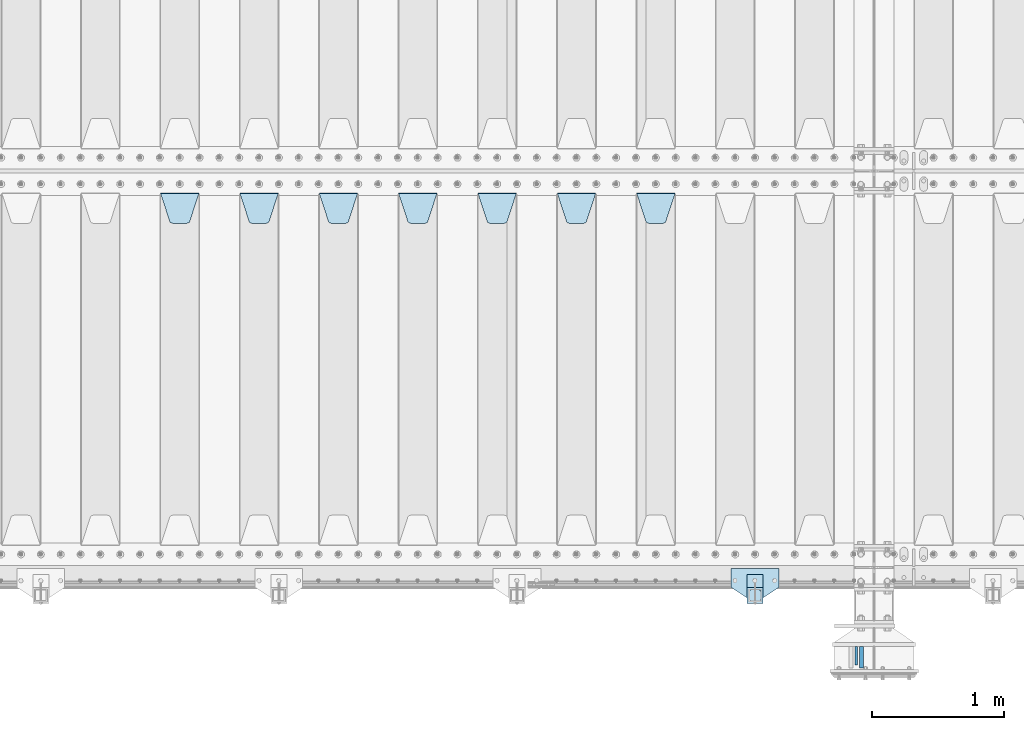
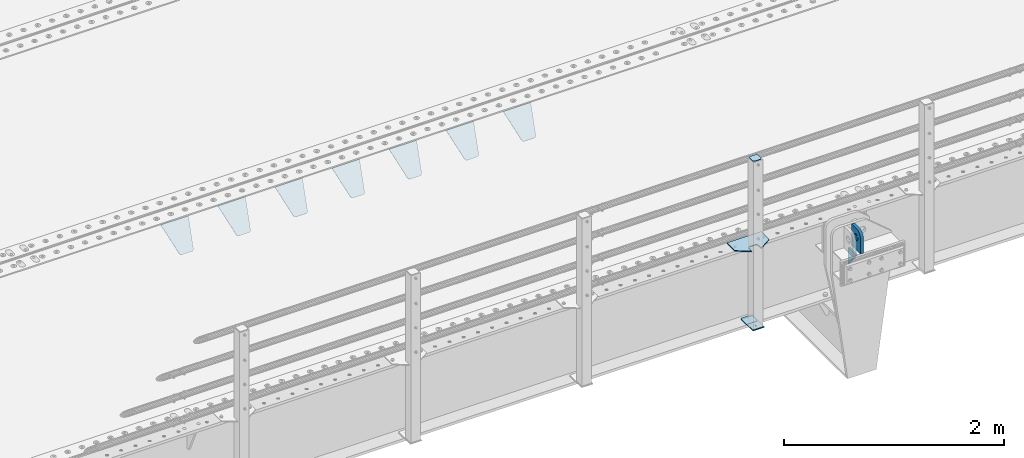
# One storey, part 204 of 247: 13 plates.
"""IFC2X3 building model written with IfcOpenShell, lengths in millimetres."""

from ifc_helpers import new_model, si_unit, frame, origin_with_axes, place, context, subcontext, project, spatial, faceted_brep, material, type_object, element, save


model = new_model("IFC2X3")

# Units and contexts
model_context = context("Model", 3, precision=1e-05, world=origin_with_axes())
body_context = subcontext(model_context, "Body", "Model", "MODEL_VIEW")
ifc_project = project(units=[si_unit("LENGTHUNIT", "METRE", prefix="MILLI"), si_unit("AREAUNIT", "SQUARE_METRE"), si_unit("VOLUMEUNIT", "CUBIC_METRE"), si_unit("MASSUNIT", "GRAM", prefix="KILO"), si_unit("TIMEUNIT", "SECOND"), si_unit("PLANEANGLEUNIT", "RADIAN"), si_unit("SOLIDANGLEUNIT", "STERADIAN"), si_unit("THERMODYNAMICTEMPERATUREUNIT", "DEGREE_CELSIUS"), si_unit("LUMINOUSINTENSITYUNIT", "LUMEN")], contexts=[model_context])

# Site, building, storey
site_placement = place(None, origin_with_axes())
site = spatial("IfcSite", under=ifc_project, at=site_placement, CompositionType="ELEMENT")
building_placement = place(site_placement, origin_with_axes())
building = spatial("IfcBuilding", under=site, at=building_placement, Name="Standard", CompositionType="ELEMENT")
storey_placement = place(building_placement, origin_with_axes())
storey = spatial("IfcBuildingStorey", under=building, at=storey_placement, Name="Undefined", CompositionType="ELEMENT", Elevation=0.0)

# Plates
ifc_material_1 = material(Name="STEEL/S355N")
plate_type_1 = type_object("IfcPlateType", PredefinedType="NOTDEFINED")
plate_1_placement = place(storey_placement, frame((12154.4999999752, -594.999999983517, -1.82219628186431e-05), z_axis=(0.0, -0.999999999999548, -9.5100000000016e-07), x_axis=(0.0, 0.0, 1.0)))
element("IfcPlate", 1, at=plate_1_placement, inside=storey, type_object=plate_type_1, material=ifc_material_1, context=body_context, shape_type="Brep", body=[
    faceted_brep([(113.837049096098, 15.0, 53.837049096097), (113.837049096098, -15.0, 53.837049096097), (125.840713002492, -15.0, 45.8164572970818), (125.840713002492, 15.0, 45.8164572970818), (105.816457297082, 15.0, 65.8407130024916), (105.816457297082, -15.0, 65.8407130024916), (103.0, 15.0, 80.0), (103.0, -15.0, 80.0), (105.816457297082, 15.0, 94.1592869975084), (105.816457297082, -15.0, 94.1592869975084), (113.837049096098, 15.0, 106.162950903903), (113.837049096098, -15.0, 106.162950903903), (125.840713002492, 15.0, 114.183542702918), (125.840713002492, -15.0, 114.183542702918), (140.0, 15.0, 117.0), (140.0, -15.0, 117.0), (154.159286997508, 15.0, 114.183542702918), (154.159286997508, -15.0, 114.183542702918), (166.162950903902, 15.0, 106.162950903903), (166.162950903902, -15.0, 106.162950903903), (174.183542702918, 15.0, 94.1592869975084), (174.183542702918, -15.0, 94.1592869975084), (177.0, 15.0, 80.0), (177.0, -15.0, 80.0), (174.183542702918, 15.0, 65.8407130024916), (174.183542702918, -15.0, 65.8407130024916), (166.162950903902, 15.0, 53.837049096097), (166.162950903902, -15.0, 53.837049096097), (154.159286997508, 15.0, 45.8164572970818), (154.159286997508, -15.0, 45.8164572970818), (140.0, 15.0, 43.0), (140.0, -15.0, 43.0), (240.0, -15.0, 0.0), (240.001666876698, -15.0000000000018, 94.9959403776223), (237.616787699976, -15.0000000000018, 113.113322498935), (230.624045898169, -15.0000000000018, 129.996116868067), (219.499985670386, -15.0000000000018, 144.493787979863), (205.002693976271, -15.0000000000018, 155.618342674451), (188.120138118986, -15.0000000000018, 162.611660295065), (170.002837349484, -15.0000000000018, 164.997157401461), (0.0, -15.0, 165.0), (0.0, -15.0, 0.0), (0.0, 15.0, 0.0), (240.0, 15.0, 0.0), (240.001666876698, 14.9999999999982, 94.9959403776223), (237.616787699976, 14.9999999999982, 113.113322498935), (230.624045898169, 14.9999999999982, 129.996116868067), (219.499985670386, 14.9999999999982, 144.493787979863), (205.002693976271, 14.9999999999982, 155.618342674451), (188.120138118986, 14.9999999999982, 162.611660295065), (170.002837349484, 14.9999999999982, 164.997157401461), (0.0, 15.0, 165.0)], [[[0, 1, 2, 3]], [[4, 5, 1, 0]], [[6, 7, 5, 4]], [[8, 9, 7, 6]], [[10, 11, 9, 8]], [[12, 13, 11, 10]], [[14, 15, 13, 12]], [[16, 17, 15, 14]], [[18, 19, 17, 16]], [[20, 21, 19, 18]], [[22, 23, 21, 20]], [[24, 25, 23, 22]], [[26, 27, 25, 24]], [[28, 29, 27, 26]], [[30, 31, 29, 28]], [[3, 2, 31, 30]], [[32, 33, 34, 35, 36, 37, 38, 39, 40, 41], [19, 21, 23, 25, 27, 29, 31, 2, 1, 5, 7, 9, 11, 13, 15, 17]], [[32, 41, 42, 43]], [[33, 32, 43, 44]], [[34, 33, 44, 45]], [[35, 34, 45, 46]], [[36, 35, 46, 47]], [[37, 36, 47, 48]], [[38, 37, 48, 49]], [[39, 38, 49, 50]], [[40, 39, 50, 51]], [[41, 40, 51, 42]], [[50, 49, 48, 47, 46, 45, 44, 43, 42, 51], [10, 8, 6, 4, 0, 3, 30, 28, 26, 24, 22, 20, 18, 16, 14, 12]]]),
])
plate_type_2 = type_object("IfcPlateType", PredefinedType="NOTDEFINED")
plate_2_placement = place(storey_placement, frame((12114.4999999769, -734.999999983535, -14.0000182219301), z_axis=(0.0, 0.0, -1.0), x_axis=(0.0, 1.0, 0.0)))
element("IfcPlate", 2, at=plate_2_placement, inside=storey, type_object=plate_type_2, material=ifc_material_1, context=body_context, shape_type="Brep", body=[
    faceted_brep([(-5.6843418860808e-14, -9.99999999999989, 3.5527136788005e-15), (140.0, -10.0, 180.0), (140.0, 10.0, 180.0), (-5.6843418860808e-14, 10.0000000000001, 3.5527136788005e-15), (140.0, -10.0, -1.81898940354586e-12), (140.0, 10.0, -1.81898940354586e-12)], [[[0, 1, 2, 3]], [[1, 4, 5, 2]], [[4, 0, 3, 5]], [[5, 3, 2]], [[4, 1, 0]]]),
])
plate_type_3 = type_object("IfcPlateType", PredefinedType="NOTDEFINED")
plate_3_placement = place(storey_placement, frame((10455.0, 2831.76776695594, -1.767766952965), z_axis=(0.0, -0.707106781186548, -0.707106781186547), x_axis=(1.0, 0.0, 0.0)))
element("IfcPlate", 3, at=plate_3_placement, inside=storey, type_object=plate_type_3, material=ifc_material_1, context=body_context, shape_type="Brep", body=[
    faceted_brep([(0.0, -2.49999999999909, 0.0), (69.345504679477, -2.5, 300.17173142483), (69.345504679477, 2.50000000000091, 300.171731424831), (0.0, 2.5, -9.09494701772928e-13), (70.9274061199576, -2.5, 304.897442415399), (70.9274061199576, 2.50000000000091, 304.8974424154), (73.3818627772307, -2.49999999999909, 309.234538108527), (73.3818627772307, 2.5, 309.234538108526), (76.6187032999551, -2.5, 313.023683126102), (76.6187032999551, 2.50000000000091, 313.023683126102), (80.5190132704993, -2.49999999999909, 316.125672595371), (80.5190132704993, 2.50000000000091, 316.125672595372), (84.9395038596849, -2.49999999999909, 318.426546230476), (84.9395038596849, 2.5, 318.426546230475), (89.7177759439219, -2.5, 319.841774983274), (89.7177759439219, 2.50000000000091, 319.841774983275), (94.678286292652, -2.5, 320.319366455077), (94.678286292652, 2.50000000000091, 320.319366455077), (195.321713707348, -2.5, 320.319366455077), (195.321713707348, 2.50000000000091, 320.319366455077), (200.282224056078, -2.5, 319.841774983274), (200.282224056078, 2.50000000000091, 319.841774983275), (205.060496140315, -2.5, 318.426546230475), (205.060496140315, 2.5, 318.426546230474), (209.480986729501, -2.49999999999818, 316.12567259537), (209.480986729501, 2.50000000000091, 316.12567259537), (213.381296700045, -2.5, 313.023683126101), (213.381296700045, 2.50000000000091, 313.023683126101), (216.618137222769, -2.5, 309.234538108525), (216.618137222769, 2.5, 309.234538108525), (219.072593880042, -2.49999999999909, 304.897442415398), (219.072593880042, 2.5, 304.897442415398), (220.654495320523, -2.5, 300.17173142483), (220.654495320523, 2.50000000000091, 300.171731424831), (290.0, -2.49999999999909, 0.0), (290.0, 2.5, -9.09494701772928e-13)], [[[0, 1, 2, 3]], [[1, 4, 5, 2]], [[4, 6, 7, 5]], [[6, 8, 9, 7]], [[8, 10, 11, 9]], [[10, 12, 13, 11]], [[12, 14, 15, 13]], [[14, 16, 17, 15]], [[16, 18, 19, 17]], [[18, 20, 21, 19]], [[20, 22, 23, 21]], [[22, 24, 25, 23]], [[24, 26, 27, 25]], [[26, 28, 29, 27]], [[28, 30, 31, 29]], [[30, 32, 33, 31]], [[32, 34, 35, 33]], [[34, 0, 3, 35]], [[5, 7, 9, 11, 13, 15, 17, 19, 21, 23, 25, 27, 29, 31, 33, 35, 3, 2]], [[34, 32, 30, 28, 26, 24, 22, 20, 18, 16, 14, 12, 10, 8, 6, 4, 1, 0]]]),
])
plate_4_placement = place(storey_placement, frame((9855.0, 2831.76776695594, -1.767766952965), z_axis=(0.0, -0.707106781186548, -0.707106781186547), x_axis=(1.0, 0.0, 0.0)))
element("IfcPlate", 4, at=plate_4_placement, inside=storey, type_object=plate_type_3, material=ifc_material_1, context=body_context, shape_type="Brep", body=[
    faceted_brep([(0.0, -2.49999999999909, 0.0), (69.345504679477, -2.5, 300.17173142483), (69.345504679477, 2.50000000000091, 300.171731424831), (0.0, 2.5, -9.09494701772928e-13), (70.9274061199576, -2.5, 304.897442415399), (70.9274061199576, 2.50000000000091, 304.8974424154), (73.3818627772307, -2.49999999999909, 309.234538108527), (73.3818627772307, 2.5, 309.234538108526), (76.6187032999551, -2.5, 313.023683126102), (76.6187032999551, 2.50000000000091, 313.023683126102), (80.5190132704993, -2.49999999999909, 316.125672595371), (80.5190132704993, 2.50000000000091, 316.125672595372), (84.9395038596849, -2.49999999999909, 318.426546230476), (84.9395038596849, 2.5, 318.426546230475), (89.7177759439219, -2.5, 319.841774983274), (89.7177759439219, 2.50000000000091, 319.841774983275), (94.678286292652, -2.5, 320.319366455077), (94.678286292652, 2.50000000000091, 320.319366455077), (195.321713707348, -2.5, 320.319366455077), (195.321713707348, 2.50000000000091, 320.319366455077), (200.282224056078, -2.5, 319.841774983274), (200.282224056078, 2.50000000000091, 319.841774983275), (205.060496140315, -2.5, 318.426546230475), (205.060496140315, 2.5, 318.426546230474), (209.480986729501, -2.49999999999818, 316.12567259537), (209.480986729501, 2.50000000000091, 316.12567259537), (213.381296700045, -2.5, 313.023683126101), (213.381296700045, 2.50000000000091, 313.023683126101), (216.618137222769, -2.5, 309.234538108525), (216.618137222769, 2.5, 309.234538108525), (219.072593880042, -2.49999999999909, 304.897442415398), (219.072593880042, 2.5, 304.897442415398), (220.654495320523, -2.5, 300.17173142483), (220.654495320523, 2.50000000000091, 300.171731424831), (290.0, -2.49999999999909, 0.0), (290.0, 2.5, -9.09494701772928e-13)], [[[0, 1, 2, 3]], [[1, 4, 5, 2]], [[4, 6, 7, 5]], [[6, 8, 9, 7]], [[8, 10, 11, 9]], [[10, 12, 13, 11]], [[12, 14, 15, 13]], [[14, 16, 17, 15]], [[16, 18, 19, 17]], [[18, 20, 21, 19]], [[20, 22, 23, 21]], [[22, 24, 25, 23]], [[24, 26, 27, 25]], [[26, 28, 29, 27]], [[28, 30, 31, 29]], [[30, 32, 33, 31]], [[32, 34, 35, 33]], [[34, 0, 3, 35]], [[5, 7, 9, 11, 13, 15, 17, 19, 21, 23, 25, 27, 29, 31, 33, 35, 3, 2]], [[34, 32, 30, 28, 26, 24, 22, 20, 18, 16, 14, 12, 10, 8, 6, 4, 1, 0]]]),
])
plate_5_placement = place(storey_placement, frame((9255.0, 2831.76776695594, -1.767766952965), z_axis=(0.0, -0.707106781186548, -0.707106781186547), x_axis=(1.0, 0.0, 0.0)))
element("IfcPlate", 5, at=plate_5_placement, inside=storey, type_object=plate_type_3, material=ifc_material_1, context=body_context, shape_type="Brep", body=[
    faceted_brep([(0.0, -2.49999999999909, 0.0), (69.345504679477, -2.5, 300.17173142483), (69.345504679477, 2.50000000000091, 300.171731424831), (0.0, 2.5, -9.09494701772928e-13), (70.9274061199576, -2.5, 304.897442415399), (70.9274061199576, 2.50000000000091, 304.8974424154), (73.3818627772307, -2.49999999999909, 309.234538108527), (73.3818627772307, 2.5, 309.234538108526), (76.6187032999551, -2.5, 313.023683126102), (76.6187032999551, 2.50000000000091, 313.023683126102), (80.5190132704993, -2.49999999999909, 316.125672595371), (80.5190132704993, 2.50000000000091, 316.125672595372), (84.9395038596849, -2.49999999999909, 318.426546230476), (84.9395038596849, 2.5, 318.426546230475), (89.7177759439219, -2.5, 319.841774983274), (89.7177759439219, 2.50000000000091, 319.841774983275), (94.678286292652, -2.5, 320.319366455077), (94.678286292652, 2.50000000000091, 320.319366455077), (195.321713707348, -2.5, 320.319366455077), (195.321713707348, 2.50000000000091, 320.319366455077), (200.282224056078, -2.5, 319.841774983274), (200.282224056078, 2.50000000000091, 319.841774983275), (205.060496140315, -2.5, 318.426546230475), (205.060496140315, 2.5, 318.426546230474), (209.480986729501, -2.49999999999818, 316.12567259537), (209.480986729501, 2.50000000000091, 316.12567259537), (213.381296700045, -2.5, 313.023683126101), (213.381296700045, 2.50000000000091, 313.023683126101), (216.618137222769, -2.5, 309.234538108525), (216.618137222769, 2.5, 309.234538108525), (219.072593880042, -2.49999999999909, 304.897442415398), (219.072593880042, 2.5, 304.897442415398), (220.654495320523, -2.5, 300.17173142483), (220.654495320523, 2.50000000000091, 300.171731424831), (290.0, -2.49999999999909, 0.0), (290.0, 2.5, -9.09494701772928e-13)], [[[0, 1, 2, 3]], [[1, 4, 5, 2]], [[4, 6, 7, 5]], [[6, 8, 9, 7]], [[8, 10, 11, 9]], [[10, 12, 13, 11]], [[12, 14, 15, 13]], [[14, 16, 17, 15]], [[16, 18, 19, 17]], [[18, 20, 21, 19]], [[20, 22, 23, 21]], [[22, 24, 25, 23]], [[24, 26, 27, 25]], [[26, 28, 29, 27]], [[28, 30, 31, 29]], [[30, 32, 33, 31]], [[32, 34, 35, 33]], [[34, 0, 3, 35]], [[5, 7, 9, 11, 13, 15, 17, 19, 21, 23, 25, 27, 29, 31, 33, 35, 3, 2]], [[34, 32, 30, 28, 26, 24, 22, 20, 18, 16, 14, 12, 10, 8, 6, 4, 1, 0]]]),
])
plate_6_placement = place(storey_placement, frame((8655.0, 2831.76776695594, -1.767766952965), z_axis=(0.0, -0.707106781186548, -0.707106781186547), x_axis=(1.0, 0.0, 0.0)))
element("IfcPlate", 6, at=plate_6_placement, inside=storey, type_object=plate_type_3, material=ifc_material_1, context=body_context, shape_type="Brep", body=[
    faceted_brep([(0.0, -2.49999999999909, 0.0), (69.345504679477, -2.5, 300.17173142483), (69.345504679477, 2.50000000000091, 300.171731424831), (0.0, 2.5, -9.09494701772928e-13), (70.9274061199576, -2.5, 304.897442415399), (70.9274061199576, 2.50000000000091, 304.8974424154), (73.3818627772307, -2.49999999999909, 309.234538108527), (73.3818627772307, 2.5, 309.234538108526), (76.6187032999551, -2.5, 313.023683126102), (76.6187032999551, 2.50000000000091, 313.023683126102), (80.5190132704993, -2.49999999999909, 316.125672595371), (80.5190132704993, 2.50000000000091, 316.125672595372), (84.9395038596849, -2.49999999999909, 318.426546230476), (84.9395038596849, 2.5, 318.426546230475), (89.7177759439219, -2.5, 319.841774983274), (89.7177759439219, 2.50000000000091, 319.841774983275), (94.678286292652, -2.5, 320.319366455077), (94.678286292652, 2.50000000000091, 320.319366455077), (195.321713707348, -2.5, 320.319366455077), (195.321713707348, 2.50000000000091, 320.319366455077), (200.282224056078, -2.5, 319.841774983274), (200.282224056078, 2.50000000000091, 319.841774983275), (205.060496140315, -2.5, 318.426546230475), (205.060496140315, 2.5, 318.426546230474), (209.480986729501, -2.49999999999818, 316.12567259537), (209.480986729501, 2.50000000000091, 316.12567259537), (213.381296700045, -2.5, 313.023683126101), (213.381296700045, 2.50000000000091, 313.023683126101), (216.618137222769, -2.5, 309.234538108525), (216.618137222769, 2.5, 309.234538108525), (219.072593880042, -2.49999999999909, 304.897442415398), (219.072593880042, 2.5, 304.897442415398), (220.654495320523, -2.5, 300.17173142483), (220.654495320523, 2.50000000000091, 300.171731424831), (290.0, -2.49999999999909, 0.0), (290.0, 2.5, -9.09494701772928e-13)], [[[0, 1, 2, 3]], [[1, 4, 5, 2]], [[4, 6, 7, 5]], [[6, 8, 9, 7]], [[8, 10, 11, 9]], [[10, 12, 13, 11]], [[12, 14, 15, 13]], [[14, 16, 17, 15]], [[16, 18, 19, 17]], [[18, 20, 21, 19]], [[20, 22, 23, 21]], [[22, 24, 25, 23]], [[24, 26, 27, 25]], [[26, 28, 29, 27]], [[28, 30, 31, 29]], [[30, 32, 33, 31]], [[32, 34, 35, 33]], [[34, 0, 3, 35]], [[5, 7, 9, 11, 13, 15, 17, 19, 21, 23, 25, 27, 29, 31, 33, 35, 3, 2]], [[34, 32, 30, 28, 26, 24, 22, 20, 18, 16, 14, 12, 10, 8, 6, 4, 1, 0]]]),
])
plate_7_placement = place(storey_placement, frame((8055.0, 2831.76776695594, -1.767766952965), z_axis=(0.0, -0.707106781186548, -0.707106781186547), x_axis=(1.0, 0.0, 0.0)))
element("IfcPlate", 7, at=plate_7_placement, inside=storey, type_object=plate_type_3, material=ifc_material_1, context=body_context, shape_type="Brep", body=[
    faceted_brep([(0.0, -2.49999999999909, 0.0), (69.345504679477, -2.5, 300.17173142483), (69.345504679477, 2.50000000000091, 300.171731424831), (0.0, 2.5, -9.09494701772928e-13), (70.9274061199576, -2.5, 304.897442415399), (70.9274061199576, 2.50000000000091, 304.8974424154), (73.3818627772307, -2.49999999999909, 309.234538108527), (73.3818627772307, 2.5, 309.234538108526), (76.6187032999551, -2.5, 313.023683126102), (76.6187032999551, 2.50000000000091, 313.023683126102), (80.5190132704993, -2.49999999999909, 316.125672595371), (80.5190132704993, 2.50000000000091, 316.125672595372), (84.9395038596849, -2.49999999999909, 318.426546230476), (84.9395038596849, 2.5, 318.426546230475), (89.7177759439219, -2.5, 319.841774983274), (89.7177759439219, 2.50000000000091, 319.841774983275), (94.678286292652, -2.5, 320.319366455077), (94.678286292652, 2.50000000000091, 320.319366455077), (195.321713707348, -2.5, 320.319366455077), (195.321713707348, 2.50000000000091, 320.319366455077), (200.282224056078, -2.5, 319.841774983274), (200.282224056078, 2.50000000000091, 319.841774983275), (205.060496140315, -2.5, 318.426546230475), (205.060496140315, 2.5, 318.426546230474), (209.480986729501, -2.49999999999818, 316.12567259537), (209.480986729501, 2.50000000000091, 316.12567259537), (213.381296700045, -2.5, 313.023683126101), (213.381296700045, 2.50000000000091, 313.023683126101), (216.618137222769, -2.5, 309.234538108525), (216.618137222769, 2.5, 309.234538108525), (219.072593880042, -2.49999999999909, 304.897442415398), (219.072593880042, 2.5, 304.897442415398), (220.654495320523, -2.5, 300.17173142483), (220.654495320523, 2.50000000000091, 300.171731424831), (290.0, -2.49999999999909, 0.0), (290.0, 2.5, -9.09494701772928e-13)], [[[0, 1, 2, 3]], [[1, 4, 5, 2]], [[4, 6, 7, 5]], [[6, 8, 9, 7]], [[8, 10, 11, 9]], [[10, 12, 13, 11]], [[12, 14, 15, 13]], [[14, 16, 17, 15]], [[16, 18, 19, 17]], [[18, 20, 21, 19]], [[20, 22, 23, 21]], [[22, 24, 25, 23]], [[24, 26, 27, 25]], [[26, 28, 29, 27]], [[28, 30, 31, 29]], [[30, 32, 33, 31]], [[32, 34, 35, 33]], [[34, 0, 3, 35]], [[5, 7, 9, 11, 13, 15, 17, 19, 21, 23, 25, 27, 29, 31, 33, 35, 3, 2]], [[34, 32, 30, 28, 26, 24, 22, 20, 18, 16, 14, 12, 10, 8, 6, 4, 1, 0]]]),
])
plate_8_placement = place(storey_placement, frame((7455.0, 2831.76776695594, -1.767766952965), z_axis=(0.0, -0.707106781186548, -0.707106781186547), x_axis=(1.0, 0.0, 0.0)))
element("IfcPlate", 8, at=plate_8_placement, inside=storey, type_object=plate_type_3, material=ifc_material_1, context=body_context, shape_type="Brep", body=[
    faceted_brep([(0.0, -2.49999999999909, 0.0), (69.345504679477, -2.5, 300.17173142483), (69.345504679477, 2.50000000000091, 300.171731424831), (0.0, 2.5, -9.09494701772928e-13), (70.9274061199576, -2.5, 304.897442415399), (70.9274061199576, 2.50000000000091, 304.8974424154), (73.3818627772307, -2.49999999999909, 309.234538108527), (73.3818627772307, 2.5, 309.234538108526), (76.6187032999551, -2.5, 313.023683126102), (76.6187032999551, 2.50000000000091, 313.023683126102), (80.5190132704993, -2.49999999999909, 316.125672595371), (80.5190132704993, 2.50000000000091, 316.125672595372), (84.9395038596849, -2.49999999999909, 318.426546230476), (84.9395038596849, 2.5, 318.426546230475), (89.7177759439219, -2.5, 319.841774983274), (89.7177759439219, 2.50000000000091, 319.841774983275), (94.678286292652, -2.5, 320.319366455077), (94.678286292652, 2.50000000000091, 320.319366455077), (195.321713707348, -2.5, 320.319366455077), (195.321713707348, 2.50000000000091, 320.319366455077), (200.282224056078, -2.5, 319.841774983274), (200.282224056078, 2.50000000000091, 319.841774983275), (205.060496140315, -2.5, 318.426546230475), (205.060496140315, 2.5, 318.426546230474), (209.480986729501, -2.49999999999818, 316.12567259537), (209.480986729501, 2.50000000000091, 316.12567259537), (213.381296700045, -2.5, 313.023683126101), (213.381296700045, 2.50000000000091, 313.023683126101), (216.618137222769, -2.5, 309.234538108525), (216.618137222769, 2.5, 309.234538108525), (219.072593880042, -2.49999999999909, 304.897442415398), (219.072593880042, 2.5, 304.897442415398), (220.654495320523, -2.5, 300.17173142483), (220.654495320523, 2.50000000000091, 300.171731424831), (290.0, -2.49999999999909, 0.0), (290.0, 2.5, -9.09494701772928e-13)], [[[0, 1, 2, 3]], [[1, 4, 5, 2]], [[4, 6, 7, 5]], [[6, 8, 9, 7]], [[8, 10, 11, 9]], [[10, 12, 13, 11]], [[12, 14, 15, 13]], [[14, 16, 17, 15]], [[16, 18, 19, 17]], [[18, 20, 21, 19]], [[20, 22, 23, 21]], [[22, 24, 25, 23]], [[24, 26, 27, 25]], [[26, 28, 29, 27]], [[28, 30, 31, 29]], [[30, 32, 33, 31]], [[32, 34, 35, 33]], [[34, 0, 3, 35]], [[5, 7, 9, 11, 13, 15, 17, 19, 21, 23, 25, 27, 29, 31, 33, 35, 3, 2]], [[34, 32, 30, 28, 26, 24, 22, 20, 18, 16, 14, 12, 10, 8, 6, 4, 1, 0]]]),
])
plate_9_placement = place(storey_placement, frame((6855.0, 2831.76776695594, -1.767766952965), z_axis=(0.0, -0.707106781186548, -0.707106781186547), x_axis=(1.0, 0.0, 0.0)))
element("IfcPlate", 9, at=plate_9_placement, inside=storey, type_object=plate_type_3, material=ifc_material_1, context=body_context, shape_type="Brep", body=[
    faceted_brep([(0.0, -2.49999999999909, 0.0), (69.345504679477, -2.5, 300.17173142483), (69.345504679477, 2.50000000000091, 300.171731424831), (0.0, 2.5, -9.09494701772928e-13), (70.9274061199576, -2.5, 304.897442415399), (70.9274061199576, 2.50000000000091, 304.8974424154), (73.3818627772307, -2.49999999999909, 309.234538108527), (73.3818627772307, 2.5, 309.234538108526), (76.6187032999551, -2.5, 313.023683126102), (76.6187032999551, 2.50000000000091, 313.023683126102), (80.5190132704993, -2.49999999999909, 316.125672595371), (80.5190132704993, 2.50000000000091, 316.125672595372), (84.9395038596849, -2.49999999999909, 318.426546230476), (84.9395038596849, 2.5, 318.426546230475), (89.7177759439219, -2.5, 319.841774983274), (89.7177759439219, 2.50000000000091, 319.841774983275), (94.678286292652, -2.5, 320.319366455077), (94.678286292652, 2.50000000000091, 320.319366455077), (195.321713707348, -2.5, 320.319366455077), (195.321713707348, 2.50000000000091, 320.319366455077), (200.282224056078, -2.5, 319.841774983274), (200.282224056078, 2.50000000000091, 319.841774983275), (205.060496140315, -2.5, 318.426546230475), (205.060496140315, 2.5, 318.426546230474), (209.480986729501, -2.49999999999818, 316.12567259537), (209.480986729501, 2.50000000000091, 316.12567259537), (213.381296700045, -2.5, 313.023683126101), (213.381296700045, 2.50000000000091, 313.023683126101), (216.618137222769, -2.5, 309.234538108525), (216.618137222769, 2.5, 309.234538108525), (219.072593880042, -2.49999999999909, 304.897442415398), (219.072593880042, 2.5, 304.897442415398), (220.654495320523, -2.5, 300.17173142483), (220.654495320523, 2.50000000000091, 300.171731424831), (290.0, -2.49999999999909, 0.0), (290.0, 2.5, -9.09494701772928e-13)], [[[0, 1, 2, 3]], [[1, 4, 5, 2]], [[4, 6, 7, 5]], [[6, 8, 9, 7]], [[8, 10, 11, 9]], [[10, 12, 13, 11]], [[12, 14, 15, 13]], [[14, 16, 17, 15]], [[16, 18, 19, 17]], [[18, 20, 21, 19]], [[20, 22, 23, 21]], [[22, 24, 25, 23]], [[24, 26, 27, 25]], [[26, 28, 29, 27]], [[28, 30, 31, 29]], [[30, 32, 33, 31]], [[32, 34, 35, 33]], [[34, 0, 3, 35]], [[5, 7, 9, 11, 13, 15, 17, 19, 21, 23, 25, 27, 29, 31, 33, 35, 3, 2]], [[34, 32, 30, 28, 26, 24, 22, 20, 18, 16, 14, 12, 10, 8, 6, 4, 1, 0]]]),
])
ifc_material_2 = material(Name="STEEL/S355J2")
plate_type_4 = type_object("IfcPlateType", PredefinedType="NOTDEFINED")
plate_10_placement = place(storey_placement, frame((11530.0, -4.99999999999636, 5.00000000004911), z_axis=(0.0, -0.999999999999548, -9.5100000000016e-07), x_axis=(-1.0, 0.0, 0.0)))
element("IfcPlate", 10, at=plate_10_placement, inside=storey, type_object=plate_type_4, material=ifc_material_2, context=body_context, shape_type="Brep", body=[
    faceted_brep([(9.04219632502645e-09, -5.00000000143385, -2.89173840428703e-09), (2.31396552408114e-06, -5.0, 145.0), (2.31396552408114e-06, 5.0, 145.0), (7.66340235713869e-09, 4.99999999856618, -2.89173840428703e-09), (130.0, -5.0, 230.0), (130.0, 5.0, 230.0), (130.0, -5.0, 180.0), (130.0, 5.0, 180.0), (130.48036798992, -5.0, 175.122741949597), (130.48036798992, 5.0, 175.122741949597), (131.903011687218, -5.0, 170.432914190873), (131.903011687218, 5.0, 170.432914190873), (134.213259692437, -5.0, 166.11074417451), (134.213259692437, 5.0, 166.11074417451), (137.322330470337, -5.0, 162.322330470337), (137.322330470337, 5.0, 162.322330470337), (141.11074417451, -5.0, 159.213259692437), (141.11074417451, 5.0, 159.213259692437), (145.432914190873, -5.0, 156.903011687218), (145.432914190873, 5.0, 156.903011687218), (150.122741949597, -5.0, 155.48036798992), (150.122741949597, 5.0, 155.48036798992), (155.0, -5.0, 155.0), (155.0, 5.0, 155.0), (205.0, -5.0, 155.0), (205.0, 5.0, 155.0), (209.877258050403, -5.0, 155.48036798992), (209.877258050403, 5.0, 155.48036798992), (214.567085809127, -5.0, 156.903011687218), (214.567085809127, 5.0, 156.903011687218), (218.88925582549, -5.0, 159.213259692437), (218.88925582549, 5.0, 159.213259692437), (222.677669529663, -5.0, 162.322330470337), (222.677669529663, 5.0, 162.322330470337), (225.786740307563, -5.0, 166.11074417451), (225.786740307563, 5.0, 166.11074417451), (228.096988312782, -5.0, 170.432914190873), (228.096988312782, 5.0, 170.432914190873), (229.51963201008, -5.0, 175.122741949597), (229.51963201008, 5.0, 175.122741949597), (230.0, -5.0, 180.0), (230.0, 5.0, 180.0), (230.0, -5.0, 230.0), (230.0, 5.0, 230.0), (360.0, -5.0, 145.0), (360.0, 5.0, 145.0), (360.0, -5.0, -7.27595761418343e-12), (360.0, 5.0, -7.27595761418343e-12)], [[[0, 1, 2, 3]], [[1, 4, 5, 2]], [[4, 6, 7, 5]], [[6, 8, 9, 7]], [[8, 10, 11, 9]], [[10, 12, 13, 11]], [[12, 14, 15, 13]], [[14, 16, 17, 15]], [[16, 18, 19, 17]], [[18, 20, 21, 19]], [[20, 22, 23, 21]], [[22, 24, 25, 23]], [[24, 26, 27, 25]], [[26, 28, 29, 27]], [[28, 30, 31, 29]], [[30, 32, 33, 31]], [[32, 34, 35, 33]], [[34, 36, 37, 35]], [[36, 38, 39, 37]], [[38, 40, 41, 39]], [[40, 42, 43, 41]], [[42, 44, 45, 43]], [[44, 46, 47, 45]], [[46, 0, 3, 47]], [[5, 7, 9, 11, 13, 15, 17, 19, 21, 23, 25, 27, 29, 31, 33, 35, 37, 39, 41, 43, 45, 47, 3, 2]], [[46, 44, 42, 40, 38, 36, 34, 32, 30, 28, 26, 24, 22, 20, 18, 16, 14, 12, 10, 8, 6, 4, 1, 0]]]),
])
plate_type_5 = type_object("IfcPlateType", PredefinedType="NOTDEFINED")
plate_11_placement = place(storey_placement, frame((11409.9999999999, -50.0000000002074, -850.000000000002), z_axis=(0.0, -0.999999999999548, -9.5100000000016e-07), x_axis=(-1.0, 0.0, 0.0)))
element("IfcPlate", 11, at=plate_11_placement, inside=storey, type_object=plate_type_5, material=ifc_material_2, context=body_context, shape_type="Brep", body=[
    faceted_brep([(53.6360389691836, -5.0, 176.363961030469), (53.6360389691836, 5.0, 176.363961030469), (59.9999999998618, 5.0, 178.999999999791), (59.9999999998618, -5.0, 178.999999999791), (66.3639610305399, 5.0, 176.363961030469), (66.3639610305399, -5.0, 176.363961030469), (68.9999999998618, 5.0, 169.999999999791), (68.9999999998618, -5.0, 169.999999999791), (66.3639610305399, 5.0, 163.636038969113), (66.3639610305399, -5.0, 163.636038969113), (59.9999999998618, 5.0, 160.999999999791), (59.9999999998618, -5.0, 160.999999999791), (53.6360389691836, 5.0, 163.636038969113), (53.6360389691836, -5.0, 163.636038969113), (50.9999999998618, 5.0, 169.999999999791), (50.9999999998618, -5.0, 169.999999999791), (120.0, -5.0, 0.0), (120.0, -5.0, 220.0), (0.0, -5.0, 220.0), (9.04219632502645e-09, -5.00000000143385, -2.89173840428703e-09), (7.66340235713869e-09, 4.99999999856618, -2.89173840428703e-09), (120.0, 5.0, 0.0), (120.0, 5.0, 220.0), (0.0, 5.0, 220.0)], [[[0, 1, 2, 3]], [[3, 2, 4, 5]], [[5, 4, 6, 7]], [[7, 6, 8, 9]], [[9, 8, 10, 11]], [[11, 10, 12, 13]], [[13, 12, 14, 15]], [[15, 14, 1, 0]], [[16, 17, 18, 19], [11, 13, 15, 0, 3, 5, 7, 9]], [[16, 19, 20, 21]], [[17, 16, 21, 22]], [[18, 17, 22, 23]], [[19, 18, 23, 20]], [[22, 21, 20, 23], [2, 1, 14, 12, 10, 8, 6, 4]]]),
])
plate_type_6 = type_object("IfcPlateType", PredefinedType="NOTDEFINED")
plate_12_placement = place(storey_placement, frame((11305.9999999999, -166.000000000207, 1012.50000000001), z_axis=(0.0, -0.999999999999548, -9.5100000000016e-07), x_axis=(1.0, 0.0, 0.0)))
element("IfcPlate", 12, at=plate_12_placement, inside=storey, type_object=plate_type_6, material=ifc_material_2, context=body_context, shape_type="Brep", body=[
    faceted_brep([(0.0, -2.5, 19.0), (0.0, -2.5, 69.0), (0.0, 2.5, 69.0), (0.0, 2.5, 19.0), (0.476369668545885, -2.5, 73.2278977451697), (0.476369668545885, 2.5, 73.2278977451697), (1.88159150985484, -2.5, 77.2437910432327), (1.88159150985484, 2.5, 77.2437910432327), (4.14520183310742, -2.5, 80.8463062353167), (4.14520183310742, 2.5, 80.8463062353167), (7.15369376468334, -2.5, 83.8547981668926), (7.15369376468334, 2.5, 83.8547981668926), (10.7562089567673, -2.5, 86.1184084901452), (10.7562089567673, 2.5, 86.1184084901452), (14.7721022548303, -2.5, 87.5236303314541), (14.7721022548303, 2.5, 87.5236303314541), (19.0, -2.5, 88.0), (19.0, 2.5, 88.0), (69.0, -2.5, 88.0), (69.0, 2.5, 88.0), (73.2278977451697, -2.5, 87.5236303314541), (73.2278977451697, 2.5, 87.5236303314541), (77.2437910432327, -2.5, 86.1184084901452), (77.2437910432327, 2.5, 86.1184084901452), (80.8463062353167, -2.5, 83.8547981668926), (80.8463062353167, 2.5, 83.8547981668926), (83.8547981668926, -2.5, 80.8463062353167), (83.8547981668926, 2.5, 80.8463062353167), (86.1184084901452, -2.5, 77.2437910432327), (86.1184084901452, 2.5, 77.2437910432327), (87.5236303314541, -2.5, 73.2278977451697), (87.5236303314541, 2.5, 73.2278977451697), (88.0, -2.5, 69.0), (88.0, 2.5, 69.0), (88.0, -2.5, 19.0), (88.0, 2.5, 19.0), (87.5236303314541, -2.5, 14.7721022548303), (87.5236303314541, 2.5, 14.7721022548303), (86.1184084901452, -2.5, 10.7562089567673), (86.1184084901452, 2.5, 10.7562089567673), (83.8547981668926, -2.5, 7.15369376468334), (83.8547981668926, 2.5, 7.15369376468334), (80.8463062353167, -2.5, 4.14520183310742), (80.8463062353167, 2.5, 4.14520183310742), (77.2437910432345, -2.5, 1.88159150985484), (77.2437910432345, 2.5, 1.88159150985484), (73.2278977451697, -2.5, 0.476369668545885), (73.2278977451697, 2.5, 0.476369668545885), (69.0, -2.5, 0.0), (69.0, 2.5, 0.0), (19.0, -2.5, 0.0), (19.0, 2.5, 0.0), (14.7721022548303, -2.5, 0.476369668545885), (14.7721022548303, 2.5, 0.476369668545885), (10.7562089567673, -2.5, 1.88159150985484), (10.7562089567673, 2.5, 1.88159150985484), (7.15369376468334, -2.5, 4.14520183310742), (7.15369376468334, 2.5, 4.14520183310742), (4.14520183310742, -2.5, 7.15369376468334), (4.14520183310742, 2.5, 7.15369376468334), (1.88159150985484, -2.5, 10.7562089567673), (1.88159150985484, 2.5, 10.7562089567673), (0.476369668545885, -2.5, 14.7721022548303), (0.476369668545885, 2.5, 14.7721022548303)], [[[0, 1, 2, 3]], [[1, 4, 5, 2]], [[4, 6, 7, 5]], [[6, 8, 9, 7]], [[8, 10, 11, 9]], [[10, 12, 13, 11]], [[12, 14, 15, 13]], [[14, 16, 17, 15]], [[16, 18, 19, 17]], [[18, 20, 21, 19]], [[20, 22, 23, 21]], [[22, 24, 25, 23]], [[24, 26, 27, 25]], [[26, 28, 29, 27]], [[28, 30, 31, 29]], [[30, 32, 33, 31]], [[32, 34, 35, 33]], [[34, 36, 37, 35]], [[36, 38, 39, 37]], [[38, 40, 41, 39]], [[40, 42, 43, 41]], [[42, 44, 45, 43]], [[44, 46, 47, 45]], [[46, 48, 49, 47]], [[48, 50, 51, 49]], [[50, 52, 53, 51]], [[52, 54, 55, 53]], [[54, 56, 57, 55]], [[56, 58, 59, 57]], [[58, 60, 61, 59]], [[60, 62, 63, 61]], [[62, 0, 3, 63]], [[5, 7, 9, 11, 13, 15, 17, 19, 21, 23, 25, 27, 29, 31, 33, 35, 37, 39, 41, 43, 45, 47, 49, 51, 53, 55, 57, 59, 61, 63, 3, 2]], [[62, 60, 58, 56, 54, 52, 50, 48, 46, 44, 42, 40, 38, 36, 34, 32, 30, 28, 26, 24, 22, 20, 18, 16, 14, 12, 10, 8, 6, 4, 1, 0]]]),
])
plate_type_7 = type_object("IfcPlateType", PredefinedType="NOTDEFINED")
plate_13_placement = place(storey_placement, frame((11409.9999999999, -50.0000000002074, -857.500000000002), z_axis=(0.0, -0.999999999999548, -9.5100000000016e-07), x_axis=(-1.0, 0.0, 0.0)))
element("IfcPlate", 13, at=plate_13_placement, inside=storey, type_object=plate_type_7, material=ifc_material_2, context=body_context, shape_type="Brep", body=[
    faceted_brep([(0.0, -2.49999999999909, 0.0), (0.0, -2.5, 100.0), (0.0, 2.5, 100.0), (0.0, 2.5, -9.09494701772928e-13), (120.0, -2.5, 100.0), (120.0, 2.5, 100.0), (120.0, -2.5, 0.0), (120.0, 2.5, 0.0)], [[[0, 1, 2, 3]], [[1, 4, 5, 2]], [[4, 6, 7, 5]], [[6, 0, 3, 7]], [[5, 7, 3, 2]], [[6, 4, 1, 0]]]),
])

save(model, "model.ifc")
